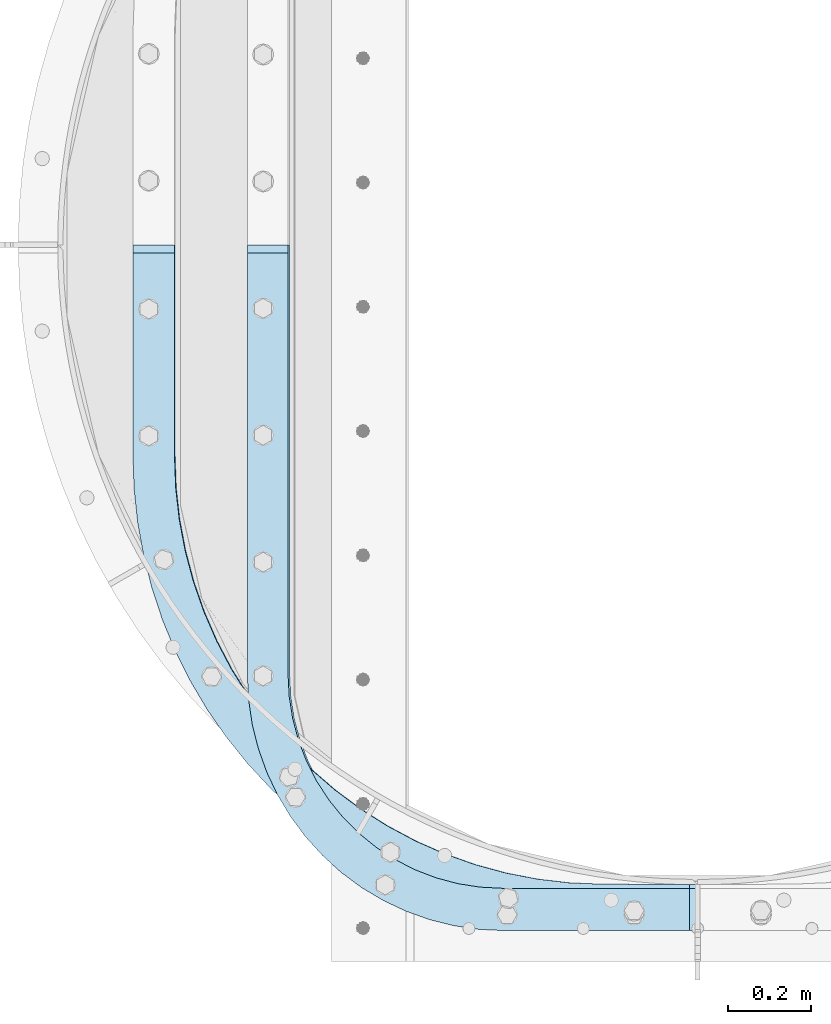
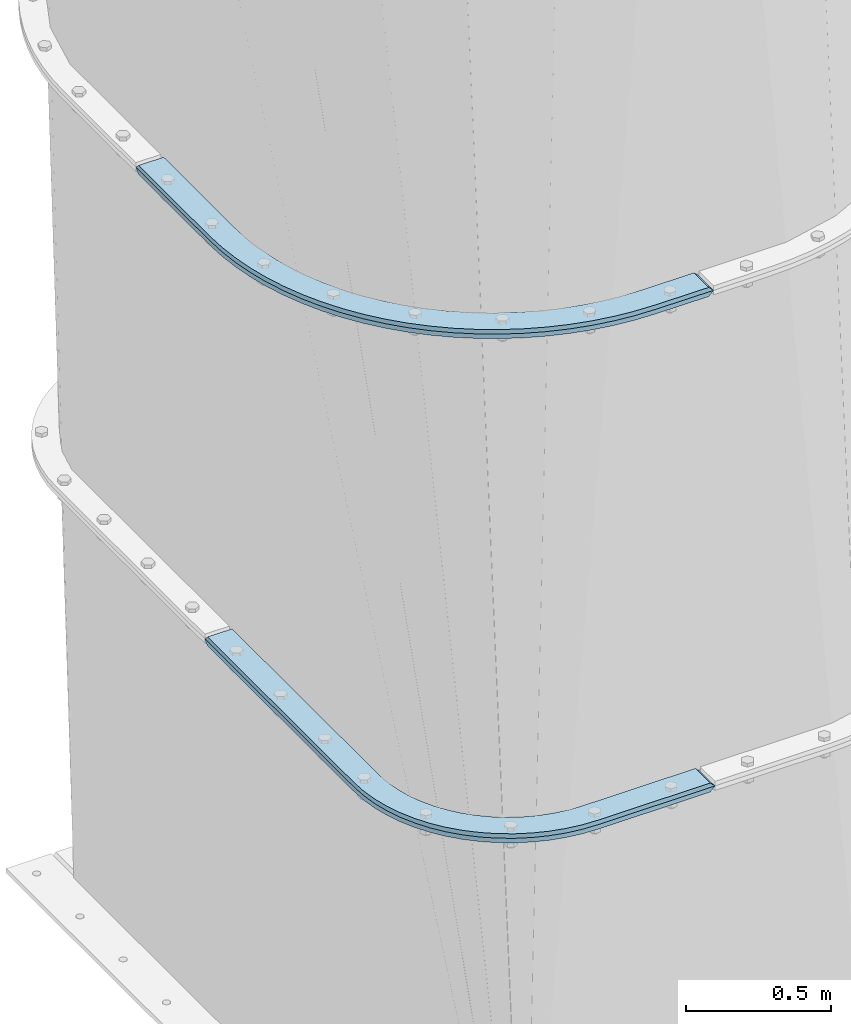
# One storey, part 10 of 15: 4 plates, 3 elements without a shape of their own.
"""IFC2X3 building model written with IfcOpenShell, lengths in millimetres."""

from ifc_helpers import new_model, si_unit, frame, origin_with_axes, place, context, subcontext, project, spatial, faceted_brep, material, type_object, element, aggregate, save


model = new_model("IFC2X3")

# Units and contexts
model_context = context("Model", 3, precision=1e-05, world=origin_with_axes())
body_context = subcontext(model_context, "Body", "Model", "MODEL_VIEW")
ifc_project = project(units=[si_unit("LENGTHUNIT", "METRE", prefix="MILLI"), si_unit("AREAUNIT", "SQUARE_METRE"), si_unit("VOLUMEUNIT", "CUBIC_METRE"), si_unit("MASSUNIT", "GRAM", prefix="KILO"), si_unit("TIMEUNIT", "SECOND"), si_unit("PLANEANGLEUNIT", "RADIAN"), si_unit("SOLIDANGLEUNIT", "STERADIAN"), si_unit("THERMODYNAMICTEMPERATUREUNIT", "DEGREE_CELSIUS"), si_unit("LUMINOUSINTENSITYUNIT", "LUMEN")], contexts=[model_context])

# Site, building, storey
site_placement = place(None, origin_with_axes())
site = spatial("IfcSite", under=ifc_project, at=site_placement, CompositionType="ELEMENT")
building_placement = place(site_placement, origin_with_axes())
building = spatial("IfcBuilding", under=site, at=building_placement, Name="Undefined", CompositionType="ELEMENT")
storey_placement = place(building_placement, origin_with_axes())
storey = spatial("IfcBuildingStorey", under=building, at=storey_placement, Name="Undefined", CompositionType="ELEMENT", Elevation=0.0)

# Assembly, plate
assembly_1_placement = place(storey_placement, origin_with_axes())
assembly_1 = element("IfcElementAssembly", 1, at=assembly_1_placement, inside=storey, Name="TRANSITION", AssemblyPlace="NOTDEFINED", PredefinedType="RIGID_FRAME")
ifc_material = material(Name="STEEL/A36")
plate_type_1 = type_object("IfcPlateType", PredefinedType="NOTDEFINED")
plate_1_placement = place(assembly_1_placement, frame((-476.623078132654, 1720.82092583339, 4192.06000019074), z_axis=(0.0, -1.0, 0.0), x_axis=(1.0, 0.0, 0.0)))
plate_1 = element("IfcPlate", 2, at=plate_1_placement, type_object=plate_type_1, material=ifc_material, Name="PLATE", context=body_context, shape_type="Brep", body=[
    faceted_brep([(99.7946649654014, 9.52500086630516, 18.991851187026), (99.7946014404297, -9.52499999999964, 0.0), (0.0, -9.52499999999964, 0.0), (8.49813987429116e-05, 9.52499999999964, 18.9922977679046), (0.00226665040457874, -9.52499999999964, 506.568496906642), (2.86552112687696, -9.52499999999964, 586.965399212112), (2.86552112687696, 9.52499999999964, 586.965399212112), (0.00226665040457874, 9.52499999999964, 506.568496906642), (11.4400606208065, -9.52499999999964, 666.955007280796), (11.4400606208065, 9.52499999999964, 666.955007280796), (25.682448871113, -9.52499999999964, 746.132115736726), (25.682448871113, 9.52499999999964, 746.132115736726), (45.5205378522613, -9.52499999999964, 824.095635103739), (45.5205378522613, 9.52499999999964, 824.095635103739), (70.8538332563299, -9.52499999999964, 900.450623614542), (70.8538332563299, 9.52499999999964, 900.450623614542), (101.554003569561, -9.52499999999964, 974.810287877187), (101.554003569561, 9.52499999999964, 974.810287877187), (137.465530164548, -9.52499999999964, 1046.79794226412), (137.465530164548, 9.52499999999964, 1046.79794226412), (178.406495114871, -9.52499999999964, 1116.04891709806), (178.406495114871, 9.52499999999964, 1116.04891709806), (224.169502741328, -9.52499999999964, 1182.2124059684), (224.169502741328, 9.52499999999964, 1182.2124059684), (274.522730221457, -9.52499999999964, 1244.95324282008), (274.522730221457, 9.52499999999964, 1244.95324282008), (329.211101940261, -9.52499999999964, 1303.95359981273), (329.211101940261, 9.52499999999964, 1303.95359981273), (387.957581633183, -9.52499999999964, 1358.9145973492), (387.957581633183, 9.52499999999964, 1358.9145973492), (450.464575775707, -9.52499999999964, 1409.55781811744), (450.464575775707, 9.52499999999964, 1409.55781811744), (516.41544111038, -9.52499999999964, 1455.62671747614), (516.41544111038, 9.52499999999964, 1455.62671747614), (585.476088674554, -9.52499999999964, 1496.88792303938), (585.476088674554, 9.52499999999964, 1496.88792303938), (657.296676203268, -9.52499999999964, 1533.13241687699), (657.296676203268, 9.52499999999964, 1533.13241687699), (731.513380334047, -9.52499999999964, 1564.176594342), (731.513380334047, 9.52499999999964, 1564.176594342), (807.750239636084, -9.52499999999964, 1589.86319416129), (807.750239636084, 9.52499999999964, 1589.86319416129), (885.621059127542, -9.52499999999964, 1610.062095078), (885.621059127542, 9.52499999999964, 1610.062095078), (964.731366633227, -9.52499999999964, 1624.6709750101), (964.731366633227, 9.52499999999964, 1624.6709750101), (1044.68041107224, -9.52499999999964, 1633.61582938589), (1044.68041107224, 9.52499999999964, 1633.61582938589), (1125.06319255282, -9.52499999999964, 1636.85134603082), (1125.06319255282, 9.52499999999964, 1636.85134603082), (1356.09818592932, -9.52500019073523, 1637.92224121094), (1337.04797114386, 9.52499999999964, 1637.83394020392), (1356.09802246094, -9.52499999999964, 1536.322265625), (1337.04797114386, 9.52499999999964, 1536.23408996477), (1123.73482538487, -9.52499999999964, 1535.24674210153), (1123.73482538487, 9.52499999999964, 1535.24674210153), (1047.10030478318, -9.52499999999964, 1532.03247607219), (1047.10030478318, 9.52499999999964, 1532.03247607219), (970.918303938195, -9.52499999999964, 1523.11709603465), (970.918303938195, 9.52499999999964, 1523.11709603465), (895.612355762711, -9.52499999999964, 1508.55016693653), (895.612355762711, 9.52499999999964, 1508.55016693653), (821.601122765285, -9.52499999999964, 1488.41267344407), (821.601122765285, 9.52499999999964, 1488.41267344407), (749.2960695011, -9.52499999999964, 1462.8165697089), (749.2960695011, 9.52499999999964, 1462.8165697089), (679.099175039733, -9.52499999999964, 1431.90415696032), (679.099175039733, 9.52499999999964, 1431.90415696032), (611.400698167385, -9.52499999999964, 1395.84729238334), (611.400698167385, 9.52499999999964, 1395.84729238334), (546.57700774787, -9.52499999999964, 1354.84643368071), (546.57700774787, 9.52499999999964, 1354.84643368071), (484.988490304467, -9.52499999999964, 1309.12952463074), (484.988490304467, 9.52499999999964, 1309.12952463074), (426.977546455406, -9.52499999999964, 1258.95072783668), (426.977546455406, 9.52499999999964, 1258.95072783668), (372.866687341763, -9.52499999999964, 1204.58901171272), (372.866687341763, 9.52499999999964, 1204.58901171272), (322.956741630674, -9.52499999999964, 1146.34659956251), (322.956741630674, 9.52499999999964, 1146.34659956251), (277.525183061995, -9.52499999999964, 1084.54728937235), (277.525183061995, 9.52499999999964, 1084.54728937235), (236.824587836399, -9.52499999999964, 1019.5346536602), (236.824587836399, 9.52499999999964, 1019.5346536602), (201.081230421042, -9.52499999999964, 951.670129388405), (201.081230421042, 9.52499999999964, 951.670129388405), (170.493825579402, -9.52499999999964, 881.331008559293), (170.493825579402, 9.52499999999964, 881.331008559293), (145.232423618945, -9.52499999999964, 808.908340664835), (145.232423618945, 9.52499999999964, 808.908340664835), (125.437464998504, -9.52499999999964, 734.804758651724), (125.437464998504, 9.52499999999964, 734.804758651724), (111.218999551242, -9.52499999999964, 659.432240488378), (111.218999551242, 9.52499999999964, 659.432240488378), (102.656074663938, -9.52499999999964, 583.209818778404), (102.656074663938, 9.52499999999964, 583.209818778404), (99.7962958139181, -9.52499999999964, 506.561251153978), (99.7962958139181, 9.52499999999964, 506.561251153978)], [[[0, 1, 2, 3]], [[4, 5, 6, 7]], [[5, 8, 9, 6]], [[8, 10, 11, 9]], [[10, 12, 13, 11]], [[12, 14, 15, 13]], [[14, 16, 17, 15]], [[16, 18, 19, 17]], [[18, 20, 21, 19]], [[20, 22, 23, 21]], [[22, 24, 25, 23]], [[24, 26, 27, 25]], [[26, 28, 29, 27]], [[28, 30, 31, 29]], [[30, 32, 33, 31]], [[32, 34, 35, 33]], [[34, 36, 37, 35]], [[36, 38, 39, 37]], [[38, 40, 41, 39]], [[40, 42, 43, 41]], [[42, 44, 45, 43]], [[44, 46, 47, 45]], [[46, 48, 49, 47]], [[49, 48, 50, 51]], [[50, 52, 53, 51]], [[54, 55, 53, 52]], [[54, 56, 57, 55]], [[56, 58, 59, 57]], [[58, 60, 61, 59]], [[60, 62, 63, 61]], [[62, 64, 65, 63]], [[64, 66, 67, 65]], [[66, 68, 69, 67]], [[68, 70, 71, 69]], [[70, 72, 73, 71]], [[72, 74, 75, 73]], [[74, 76, 77, 75]], [[76, 78, 79, 77]], [[78, 80, 81, 79]], [[80, 82, 83, 81]], [[82, 84, 85, 83]], [[84, 86, 87, 85]], [[86, 88, 89, 87]], [[88, 90, 91, 89]], [[90, 92, 93, 91]], [[92, 94, 95, 93]], [[94, 96, 97, 95]], [[7, 6, 9, 11, 13, 15, 17, 19, 21, 23, 25, 27, 29, 31, 33, 35, 37, 39, 41, 43, 45, 47, 49, 51, 53, 55, 57, 59, 61, 63, 65, 67, 69, 71, 73, 75, 77, 79, 81, 83, 85, 87, 89, 91, 93, 95, 97, 0, 3]], [[4, 7, 3, 2]], [[1, 96, 94, 92, 90, 88, 86, 84, 82, 80, 78, 76, 74, 72, 70, 68, 66, 64, 62, 60, 58, 56, 54, 52, 50, 48, 46, 44, 42, 40, 38, 36, 34, 32, 30, 28, 26, 24, 22, 20, 18, 16, 14, 12, 10, 8, 5, 4, 2]], [[97, 96, 1, 0]]]),
])
aggregate(assembly_1, [plate_1])

# Assembly, plates
assembly_2_placement = place(storey_placement, origin_with_axes())
assembly_2 = element("IfcElementAssembly", 3, at=assembly_2_placement, inside=storey, Name="TRANSITION", AssemblyPlace="NOTDEFINED", PredefinedType="RIGID_FRAME")
plate_2_placement = place(assembly_2_placement, frame((-476.623078132654, 1720.82092583339, 4173.01), z_axis=(0.0, -1.0, 0.0), x_axis=(1.0, 0.0, 0.0)))
plate_2 = element("IfcPlate", 4, at=plate_2_placement, type_object=plate_type_1, material=ifc_material, Name="PLATE", context=body_context, shape_type="Brep", body=[
    faceted_brep([(101.600061997572, -9.52500095346932, 18.9913965695221), (8.49794006967386e-05, -9.52499999999964, 18.99185122937), (0.0, 9.52499999999964, 0.0), (101.599998474121, 9.52499999999964, 0.0), (0.00226665040457874, -9.52499999999964, 506.568496906642), (2.86552112687696, -9.52499999999964, 586.965399212112), (2.86552112687696, 9.52499999999964, 586.965399212112), (0.00226665040457874, 9.52499999999964, 506.568496906642), (11.4400606208065, -9.52499999999964, 666.955007280796), (11.4400606208065, 9.52499999999964, 666.955007280796), (25.682448871113, -9.52499999999964, 746.132115736726), (25.682448871113, 9.52499999999964, 746.132115736726), (45.5205378522613, -9.52499999999964, 824.095635103739), (45.5205378522613, 9.52499999999964, 824.095635103739), (70.8538332563299, -9.52499999999964, 900.450623614542), (70.8538332563299, 9.52499999999964, 900.450623614542), (101.554003569561, -9.52499999999964, 974.810287877187), (101.554003569561, 9.52499999999964, 974.810287877187), (137.465530164548, -9.52499999999964, 1046.79794226412), (137.465530164548, 9.52499999999964, 1046.79794226412), (178.406495114871, -9.52499999999964, 1116.04891709806), (178.406495114871, 9.52499999999964, 1116.04891709806), (224.169502741328, -9.52499999999964, 1182.2124059684), (224.169502741328, 9.52499999999964, 1182.2124059684), (274.522730221457, -9.52499999999964, 1244.95324282008), (274.522730221457, 9.52499999999964, 1244.95324282008), (329.211101940261, -9.52499999999964, 1303.95359981273), (329.211101940261, 9.52499999999964, 1303.95359981273), (387.957581633183, -9.52499999999964, 1358.9145973492), (387.957581633183, 9.52499999999964, 1358.9145973492), (450.464575775707, -9.52499999999964, 1409.55781811744), (450.464575775707, 9.52499999999964, 1409.55781811744), (516.41544111038, -9.52499999999964, 1455.62671747614), (516.41544111038, 9.52499999999964, 1455.62671747614), (585.476088674554, -9.52499999999964, 1496.88792303938), (585.476088674554, 9.52499999999964, 1496.88792303938), (657.296676203268, -9.52499999999964, 1533.13241687699), (657.296676203268, 9.52499999999964, 1533.13241687699), (731.513380334047, -9.52499999999964, 1564.176594342), (731.513380334047, 9.52499999999964, 1564.176594342), (807.750239636084, -9.52499999999964, 1589.86319416129), (807.750239636084, 9.52499999999964, 1589.86319416129), (885.621059127542, -9.52499999999964, 1610.062095078), (885.621059127542, 9.52499999999964, 1610.062095078), (964.731366633227, -9.52499999999964, 1624.6709750101), (964.731366633227, 9.52499999999964, 1624.6709750101), (1044.68041107224, -9.52499999999964, 1633.61582938589), (1044.68041107224, 9.52499999999964, 1633.61582938589), (1125.06319255282, -9.52499999999964, 1636.85134603082), (1125.06319255282, 9.52499999999964, 1636.85134603082), (1337.04797114109, -9.52499999999964, 1637.83394020391), (1356.09818592933, 9.52499847412037, 1637.92224121094), (1337.04797114109, -9.52499999999964, 1536.23396306721), (1356.09802246094, 9.52499999999964, 1536.322265625), (1125.53337021302, -9.52499999999964, 1535.25353104851), (1125.53337021302, 9.52499999999964, 1535.25353104851), (1048.89919630054, -9.52499999999964, 1532.03878036735), (1048.89919630054, 9.52499999999964, 1532.03878036735), (972.717574464455, -9.52499999999964, 1523.1229670218), (972.717574464455, 9.52499999999964, 1523.1229670218), (897.41203190946, -9.52499999999964, 1508.55565794681), (897.41203190946, 9.52499999999964, 1508.55565794681), (823.401225329481, -9.52499999999964, 1488.41783923252), (823.401225329481, 9.52499999999964, 1488.41783923252), (751.096613410651, -9.52499999999964, 1462.82146588676), (751.096613410651, 9.52499999999964, 1462.82146588676), (680.900169351152, -9.52499999999964, 1431.90883942782), (680.900169351152, 9.52499999999964, 1431.90883942782), (613.202146115094, -9.52499999999964, 1395.85181676761), (613.202146115094, 9.52499999999964, 1395.85181676761), (548.378906844311, -9.52499999999964, 1354.8508547834), (548.378906844311, 9.52499999999964, 1354.8508547834), (486.790832489823, -9.52499999999964, 1309.13389588963), (486.790832489823, 9.52499999999964, 1309.13389588963), (428.780318295328, -9.52499999999964, 1258.95510080566), (428.780318295328, 9.52499999999964, 1258.95510080566), (374.669870271166, -9.52499999999964, 1204.59343556431), (374.669870271166, 9.52499999999964, 1204.59343556431), (324.7603122413, -9.52499999999964, 1146.35112061673), (324.7603122413, 9.52499999999964, 1146.35112061673), (279.32911343112, -9.52499999999964, 1084.55195065581), (279.32911343112, 9.52499999999964, 1084.55195065581), (238.628845893756, -9.52499999999964, 1019.53949449874), (238.628845893756, 9.52499999999964, 1019.53949449874), (202.885780350741, -9.52499999999964, 951.67518503657), (202.885780350741, 9.52499999999964, 951.67518503657), (172.298628253365, -9.52499999999964, 881.336309869553), (172.298628253365, 9.52499999999964, 881.336309869553), (147.037437058154, -9.52499999999964, 808.913913799081), (147.037437058154, 9.52499999999964, 808.913913799081), (127.242644858133, -9.52499999999964, 734.810624837339), (127.242644858133, 9.52499999999964, 734.810624837339), (113.024299625579, -9.52499999999964, 659.438415820769), (113.024299625579, 9.52499999999964, 659.438415820769), (104.461447406857, -9.52499999999964, 583.21631407154), (104.461447406857, 9.52499999999964, 583.21631407154), (101.601692870424, -9.52499999999964, 506.568071840215), (101.601692870424, 9.52499999999964, 506.568071840215)], [[[0, 1, 2, 3]], [[4, 5, 6, 7]], [[5, 8, 9, 6]], [[8, 10, 11, 9]], [[10, 12, 13, 11]], [[12, 14, 15, 13]], [[14, 16, 17, 15]], [[16, 18, 19, 17]], [[18, 20, 21, 19]], [[20, 22, 23, 21]], [[22, 24, 25, 23]], [[24, 26, 27, 25]], [[26, 28, 29, 27]], [[28, 30, 31, 29]], [[30, 32, 33, 31]], [[32, 34, 35, 33]], [[34, 36, 37, 35]], [[36, 38, 39, 37]], [[38, 40, 41, 39]], [[40, 42, 43, 41]], [[42, 44, 45, 43]], [[44, 46, 47, 45]], [[46, 48, 49, 47]], [[49, 48, 50, 51]], [[51, 50, 52, 53]], [[54, 55, 53, 52]], [[54, 56, 57, 55]], [[56, 58, 59, 57]], [[58, 60, 61, 59]], [[60, 62, 63, 61]], [[62, 64, 65, 63]], [[64, 66, 67, 65]], [[66, 68, 69, 67]], [[68, 70, 71, 69]], [[70, 72, 73, 71]], [[72, 74, 75, 73]], [[74, 76, 77, 75]], [[76, 78, 79, 77]], [[78, 80, 81, 79]], [[80, 82, 83, 81]], [[82, 84, 85, 83]], [[84, 86, 87, 85]], [[86, 88, 89, 87]], [[88, 90, 91, 89]], [[90, 92, 93, 91]], [[92, 94, 95, 93]], [[94, 96, 97, 95]], [[97, 96, 0, 3]], [[7, 6, 9, 11, 13, 15, 17, 19, 21, 23, 25, 27, 29, 31, 33, 35, 37, 39, 41, 43, 45, 47, 49, 51, 53, 55, 57, 59, 61, 63, 65, 67, 69, 71, 73, 75, 77, 79, 81, 83, 85, 87, 89, 91, 93, 95, 97, 3, 2]], [[4, 7, 2, 1]], [[96, 94, 92, 90, 88, 86, 84, 82, 80, 78, 76, 74, 72, 70, 68, 66, 64, 62, 60, 58, 56, 54, 52, 50, 48, 46, 44, 42, 40, 38, 36, 34, 32, 30, 28, 26, 24, 22, 20, 18, 16, 14, 12, 10, 8, 5, 4, 1, 0]]]),
])
plate_type_2 = type_object("IfcPlateType", PredefinedType="NOTDEFINED")
plate_3_placement = place(assembly_2_placement, frame((-201.964438828887, 73.9726734030219, 2110.315), z_axis=(1.0, 0.0, 0.0), x_axis=(0.0, 1.0, 0.0)))
plate_3 = element("IfcPlate", 5, at=plate_3_placement, type_object=plate_type_2, material=ifc_material, Name="PLATE", context=body_context, shape_type="Brep", body=[
    faceted_brep([(1646.87729611779, -9.52500114440909, 97.8299026491594), (1646.87731933594, -9.52500000000009, 0.0), (1627.82633602376, 9.52500000000009, 0.0), (1627.82732029037, 9.52500000000009, 97.8299026489258), (615.950011663852, -9.52500000000009, 0.0), (555.576352915146, -9.52500000000009, 2.96596766171297), (555.576352915146, 9.52500000000009, 2.96596766171297), (615.950011663852, 9.52500000000009, 0.0), (495.784125503137, -9.52500000000009, 11.8353067569387), (495.784125503137, 9.52500000000009, 11.8353067569387), (437.149161262912, -9.52500000000009, 26.5226007018123), (437.149161262912, 9.52500000000009, 26.5226007018123), (380.236146952604, -9.52500000000009, 46.8864028269114), (380.236146952604, 9.52500000000009, 46.8864028269114), (325.593186011224, -9.52500000000009, 72.7305985860049), (325.593186011224, 9.52500000000009, 72.7305985860049), (273.746520022929, -9.52500000000009, 103.806294246338), (273.746520022929, 9.52500000000009, 103.806294246338), (225.195460722895, -9.52500000000009, 139.814213871333), (225.195460722895, 9.52500000000009, 139.814213871333), (180.407581352366, -9.52500000000009, 180.40758151146), (180.407581352366, 9.52500000000009, 180.40758151146), (139.814213672743, -9.52500000000009, 225.195460846191), (139.814213672743, 9.52500000000009, 225.195460846191), (103.806294004932, -9.52500000000009, 273.746520114471), (103.806294004932, 9.52500000000009, 273.746520114471), (72.7305982988784, -9.52500000000009, 325.593186075362), (72.7305982988784, 9.52500000000009, 325.593186075362), (46.8864024915977, -9.52500000000009, 380.236146993951), (46.8864024915977, 9.52500000000009, 380.236146993951), (26.5226003163094, -9.52500000000009, 437.149161286301), (26.5226003163094, 9.52500000000009, 437.149161286301), (11.8353063197283, -9.52500000000009, 495.784125513574), (11.8353063197283, 9.52500000000009, 495.784125513574), (2.96596717177431, -9.52500000000009, 555.576352917761), (2.96596717177431, 9.52500000000009, 555.576352917761), (-5.43179524470361e-07, -9.52500000000009, 615.950011663852), (-5.43179524470361e-07, 9.52500000000009, 615.950011663852), (-9.5367431640625e-07, -9.52500000000009, 1081.43933105469), (-9.36874954504674e-07, 9.52500000000009, 1062.38933172029), (101.599998474121, -9.52499923706046, 1081.43943889868), (101.599998474121, 9.52500000000009, 1062.38933182189), (101.599998474121, -9.52500000000009, 612.179878234863), (101.599998474121, 9.52500000000009, 612.179878234863), (104.417661457707, -9.52500000000009, 558.41566570511), (104.417661457707, 9.52500000000009, 558.41566570511), (112.839779503182, -9.52500000000009, 505.240505138718), (112.839779503182, 9.52500000000009, 505.240505138718), (126.7740781228, -9.52500000000009, 453.236994722469), (126.7740781228, 9.52500000000009, 453.236994722469), (146.067890224943, -9.52500000000009, 402.974895798919), (146.067890224943, 9.52500000000009, 402.974895798919), (170.509828766731, -9.52500000000009, 355.004890441895), (170.509828766731, 9.52500000000009, 355.004890441895), (199.832102754696, -9.52500000000009, 309.852548068456), (199.832102754696, 9.52500000000009, 309.852548068456), (233.713451218945, -9.52500000000009, 268.012567190381), (233.713451218945, 9.52500000000009, 268.012567190381), (271.782663015576, -9.52500000000009, 229.94335539375), (271.782663015576, 9.52500000000009, 229.94335539375), (313.622643893651, -9.52500000000009, 196.062006929501), (313.622643893651, 9.52500000000009, 196.062006929501), (358.77498626709, -9.52500000000009, 166.739732941536), (358.77498626709, 9.52500000000009, 166.739732941536), (406.744991624115, -9.52500000000009, 142.297794399747), (406.744991624115, 9.52500000000009, 142.297794399747), (457.007090547665, -9.52500000000009, 123.003982297604), (457.007090547665, 9.52500000000009, 123.003982297604), (509.010600963913, -9.52500000000009, 109.069683677987), (509.010600963913, 9.52500000000009, 109.069683677987), (562.185761530305, -9.52500000000009, 100.647565632512), (562.185761530305, 9.52500000000009, 100.647565632512), (615.949974060059, -9.52500000000009, 97.8299026489258), (615.949974060059, 9.52500000000009, 97.8299026489258)], [[[0, 1, 2, 3]], [[4, 5, 6, 7]], [[5, 8, 9, 6]], [[8, 10, 11, 9]], [[10, 12, 13, 11]], [[12, 14, 15, 13]], [[14, 16, 17, 15]], [[16, 18, 19, 17]], [[18, 20, 21, 19]], [[20, 22, 23, 21]], [[22, 24, 25, 23]], [[24, 26, 27, 25]], [[26, 28, 29, 27]], [[28, 30, 31, 29]], [[30, 32, 33, 31]], [[32, 34, 35, 33]], [[34, 36, 37, 35]], [[37, 36, 38, 39]], [[40, 41, 39, 38]], [[42, 43, 41, 40]], [[42, 44, 45, 43]], [[44, 46, 47, 45]], [[46, 48, 49, 47]], [[48, 50, 51, 49]], [[50, 52, 53, 51]], [[52, 54, 55, 53]], [[54, 56, 57, 55]], [[56, 58, 59, 57]], [[58, 60, 61, 59]], [[60, 62, 63, 61]], [[62, 64, 65, 63]], [[64, 66, 67, 65]], [[66, 68, 69, 67]], [[68, 70, 71, 69]], [[70, 72, 73, 71]], [[73, 72, 0, 3]], [[7, 6, 9, 11, 13, 15, 17, 19, 21, 23, 25, 27, 29, 31, 33, 35, 37, 39, 41, 43, 45, 47, 49, 51, 53, 55, 57, 59, 61, 63, 65, 67, 69, 71, 73, 3, 2]], [[4, 7, 2, 1]], [[72, 70, 68, 66, 64, 62, 60, 58, 56, 54, 52, 50, 48, 46, 44, 42, 40, 38, 36, 34, 32, 30, 28, 26, 24, 22, 20, 18, 16, 14, 12, 10, 8, 5, 4, 1, 0]]]),
])
aggregate(assembly_2, [plate_2, plate_3])

# Assembly, plate
assembly_3_placement = place(storey_placement, origin_with_axes())
assembly_3 = element("IfcElementAssembly", 6, at=assembly_3_placement, inside=storey, Name="TRANSITION", AssemblyPlace="NOTDEFINED", PredefinedType="RIGID_FRAME")
plate_4_placement = place(assembly_3_placement, frame((-201.964438828887, 73.9726734030219, 2091.265), z_axis=(1.0, 0.0, 0.0), x_axis=(0.0, 1.0, 0.0)))
plate_4 = element("IfcPlate", 7, at=plate_4_placement, type_object=plate_type_2, material=ifc_material, Name="PLATE", context=body_context, shape_type="Brep", body=[
    faceted_brep([(1646.87733404866, 9.52499923706046, 101.599998473973), (1627.8283570523, -9.52500000000009, 101.599998474121), (1627.82733485471, -9.52500000000009, 0.0), (1646.87731933594, 9.52500000000009, 0.0), (615.950011663852, -9.52500000000009, 0.0), (555.576352915146, -9.52500000000009, 2.96596766171297), (555.576352915146, 9.52500000000009, 2.96596766171297), (615.950011663852, 9.52500000000009, 0.0), (495.784125503137, -9.52500000000009, 11.8353067569387), (495.784125503137, 9.52500000000009, 11.8353067569387), (437.149161262912, -9.52500000000009, 26.5226007018123), (437.149161262912, 9.52500000000009, 26.5226007018123), (380.236146952604, -9.52500000000009, 46.8864028269114), (380.236146952604, 9.52500000000009, 46.8864028269114), (325.593186011224, -9.52500000000009, 72.7305985860049), (325.593186011224, 9.52500000000009, 72.7305985860049), (273.746520022929, -9.52500000000009, 103.806294246338), (273.746520022929, 9.52500000000009, 103.806294246338), (225.195460722895, -9.52500000000009, 139.814213871333), (225.195460722895, 9.52500000000009, 139.814213871333), (180.407581352366, -9.52500000000009, 180.40758151146), (180.407581352366, 9.52500000000009, 180.40758151146), (139.814213672743, -9.52500000000009, 225.195460846191), (139.814213672743, 9.52500000000009, 225.195460846191), (103.806294004932, -9.52500000000009, 273.746520114471), (103.806294004932, 9.52500000000009, 273.746520114471), (72.7305982988784, -9.52500000000009, 325.593186075362), (72.7305982988784, 9.52500000000009, 325.593186075362), (46.8864024915977, -9.52500000000009, 380.236146993951), (46.8864024915977, 9.52500000000009, 380.236146993951), (26.5226003163094, -9.52500000000009, 437.149161286301), (26.5226003163094, 9.52500000000009, 437.149161286301), (11.8353063197283, -9.52500000000009, 495.784125513574), (11.8353063197283, 9.52500000000009, 495.784125513574), (2.96596717177431, -9.52500000000009, 555.576352917761), (2.96596717177431, 9.52500000000009, 555.576352917761), (-5.43179524470361e-07, -9.52500000000009, 615.950011663852), (-5.43179524470361e-07, 9.52500000000009, 615.950011663852), (-1.49899983625801e-06, -9.52500000000009, 1062.38933163032), (-1.52587881530053e-06, 9.52500000000009, 1081.43933105469), (101.599998474121, 9.52499923706046, 1081.43943889835), (101.599998474121, -9.52500000000009, 1062.38933173196), (101.599998474121, -9.52500000000009, 615.949974060059), (101.599998474121, 9.52500000000009, 615.949974060059), (104.417661457707, -9.52500000000009, 562.185761530306), (104.417661457707, 9.52500000000009, 562.185761530306), (112.839779503182, -9.52500000000009, 509.010600963913), (112.839779503182, 9.52500000000009, 509.010600963913), (126.7740781228, -9.52500000000009, 457.007090547665), (126.7740781228, 9.52500000000009, 457.007090547665), (146.067890224943, -9.52500000000009, 406.744991624115), (146.067890224943, 9.52500000000009, 406.744991624115), (170.509828766731, -9.52500000000009, 358.77498626709), (170.509828766731, 9.52500000000009, 358.77498626709), (199.832102754696, -9.52500000000009, 313.622643893651), (199.832102754696, 9.52500000000009, 313.622643893651), (233.713451218945, -9.52500000000009, 271.782663015577), (233.713451218945, 9.52500000000009, 271.782663015577), (271.782663015576, -9.52500000000009, 233.713451218945), (271.782663015576, 9.52500000000009, 233.713451218945), (313.622643893651, -9.52500000000009, 199.832102754696), (313.622643893651, 9.52500000000009, 199.832102754696), (358.77498626709, -9.52500000000009, 170.509828766731), (358.77498626709, 9.52500000000009, 170.509828766731), (406.744991624115, -9.52500000000009, 146.067890224943), (406.744991624115, 9.52500000000009, 146.067890224943), (457.007090547665, -9.52500000000009, 126.7740781228), (457.007090547665, 9.52500000000009, 126.7740781228), (509.010600963913, -9.52500000000009, 112.839779503182), (509.010600963913, 9.52500000000009, 112.839779503182), (562.185761530305, -9.52500000000009, 104.417661457707), (562.185761530305, 9.52500000000009, 104.417661457707), (615.949974060059, -9.52500000000009, 101.599998474121), (615.949974060059, 9.52500000000009, 101.599998474121)], [[[0, 1, 2, 3]], [[4, 5, 6, 7]], [[5, 8, 9, 6]], [[8, 10, 11, 9]], [[10, 12, 13, 11]], [[12, 14, 15, 13]], [[14, 16, 17, 15]], [[16, 18, 19, 17]], [[18, 20, 21, 19]], [[20, 22, 23, 21]], [[22, 24, 25, 23]], [[24, 26, 27, 25]], [[26, 28, 29, 27]], [[28, 30, 31, 29]], [[30, 32, 33, 31]], [[32, 34, 35, 33]], [[34, 36, 37, 35]], [[37, 36, 38, 39]], [[40, 39, 38, 41]], [[42, 43, 40, 41]], [[42, 44, 45, 43]], [[44, 46, 47, 45]], [[46, 48, 49, 47]], [[48, 50, 51, 49]], [[50, 52, 53, 51]], [[52, 54, 55, 53]], [[54, 56, 57, 55]], [[56, 58, 59, 57]], [[58, 60, 61, 59]], [[60, 62, 63, 61]], [[62, 64, 65, 63]], [[64, 66, 67, 65]], [[66, 68, 69, 67]], [[68, 70, 71, 69]], [[70, 72, 73, 71]], [[7, 6, 9, 11, 13, 15, 17, 19, 21, 23, 25, 27, 29, 31, 33, 35, 37, 39, 40, 43, 45, 47, 49, 51, 53, 55, 57, 59, 61, 63, 65, 67, 69, 71, 73, 0, 3]], [[4, 7, 3, 2]], [[72, 70, 68, 66, 64, 62, 60, 58, 56, 54, 52, 50, 48, 46, 44, 42, 41, 38, 36, 34, 32, 30, 28, 26, 24, 22, 20, 18, 16, 14, 12, 10, 8, 5, 4, 2, 1]], [[73, 72, 1, 0]]]),
])
aggregate(assembly_3, [plate_4])

save(model, "model.ifc")
